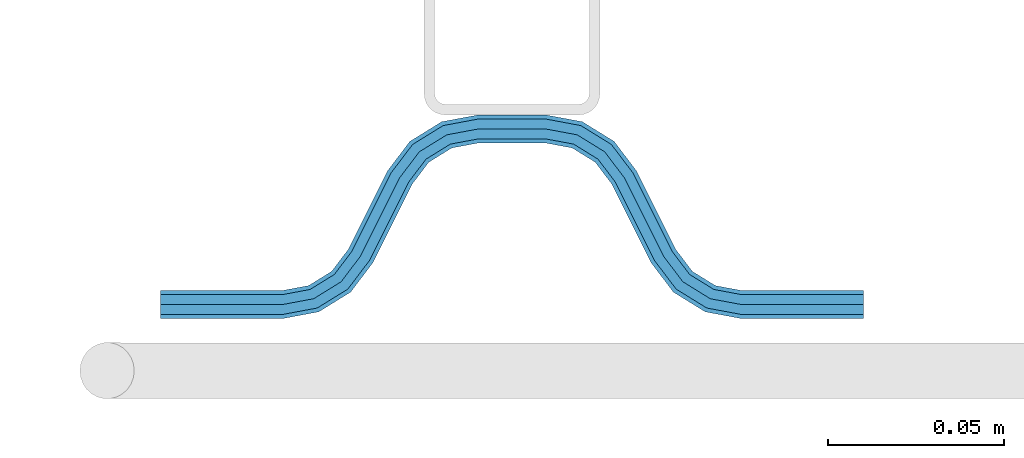
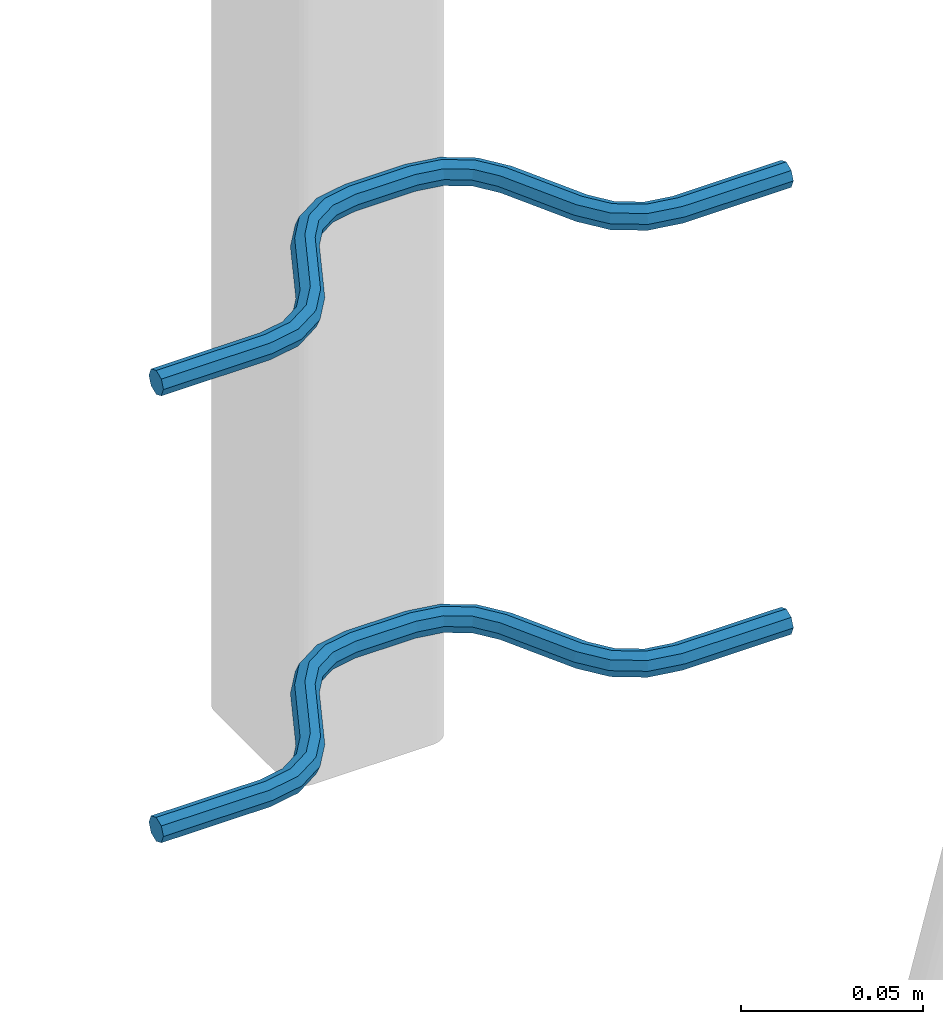
# One storey, part 4 of 5: 2 beams, 2 elements without a shape of their own.
"""IFC2X3 building model written with IfcOpenShell, lengths in millimetres."""

from ifc_helpers import new_model, si_unit, frame, origin_with_axes, place, context, subcontext, project, spatial, faceted_brep, material, type_object, element, aggregate, save


model = new_model("IFC2X3")

# Units and contexts
model_context = context("Model", 3, precision=1e-05, world=origin_with_axes())
body_context = subcontext(model_context, "Body", "Model", "MODEL_VIEW")
ifc_project = project(units=[si_unit("LENGTHUNIT", "METRE", prefix="MILLI"), si_unit("AREAUNIT", "SQUARE_METRE"), si_unit("VOLUMEUNIT", "CUBIC_METRE"), si_unit("MASSUNIT", "GRAM", prefix="KILO"), si_unit("TIMEUNIT", "SECOND"), si_unit("PLANEANGLEUNIT", "RADIAN"), si_unit("SOLIDANGLEUNIT", "STERADIAN"), si_unit("THERMODYNAMICTEMPERATUREUNIT", "DEGREE_CELSIUS"), si_unit("LUMINOUSINTENSITYUNIT", "LUMEN")], contexts=[model_context])

# Site, building, storey
site_placement = place(None, origin_with_axes())
site = spatial("IfcSite", under=ifc_project, at=site_placement, CompositionType="ELEMENT")
building_placement = place(site_placement, origin_with_axes())
building = spatial("IfcBuilding", under=site, at=building_placement, Name="Undefined", CompositionType="ELEMENT")
storey_placement = place(building_placement, origin_with_axes())
storey = spatial("IfcBuildingStorey", under=building, at=storey_placement, Name="Undefined", CompositionType="ELEMENT", Elevation=0.0)

# Assembly, beam
assembly_1_placement = place(storey_placement, origin_with_axes())
assembly_1 = element("IfcElementAssembly", 1, at=assembly_1_placement, inside=storey, Name="Steel Assembly", AssemblyPlace="NOTDEFINED", PredefinedType="NOTDEFINED")
ifc_material = material(Name="REBAR/A500HW")
beam_type = type_object("IfcBeamType", Name="D8", PredefinedType="NOTDEFINED")
beam_1_placement = place(assembly_1_placement, frame((36620.0028957805, 7595.98072202406, 2580.99992151562), z_axis=(0.0, 0.0, 1.0), x_axis=(-0.999999999544916, 3.01690000135643e-05, 0.0)))
beam_1 = element("IfcBeam", 2, at=beam_1_placement, type_object=beam_type, material=ifc_material, Name="AnchorRebar", ObjectType="D8", context=body_context, shape_type="Brep", body=[
    faceted_brep([(7.27595761418343e-12, -4.00000000000182, 0.0), (0.0, -2.82842712474667, -2.82842712474621), (34.5491497807379, -2.82842712464299, -2.82842712474621), (34.549149780345, -3.99999999990087, 0.0), (-7.27595761418343e-12, -1.81898940354586e-12, -4.0), (34.5491497807307, 1.02772901300341e-10, -4.0), (-1.45519152283669e-11, 2.82842712474485, -2.82842712474621), (34.5491497807234, 2.82842712484944, -2.82842712474621), (-2.18278728425503e-11, 3.99999999999909, 0.0), (34.5491497807234, 4.00000000010186, 0.0), (-1.45519152283669e-11, 2.82842712474485, 2.82842712474621), (34.5491497807234, 2.82842712484944, 2.82842712474621), (-7.27595761418343e-12, -1.81898940354586e-12, 4.0), (34.5491497807307, 1.02772901300341e-10, 4.0), (0.0, -2.82842712474667, 2.82842712474621), (34.5491497807379, -2.82842712464299, 2.82842712474621), (45.0102956729243, 2.04744769147965, 0.0), (44.5876751635515, 0.954756103194086, -2.82842712474621), (43.5673789981083, -1.68323474872432, -4.0), (42.5470828326725, -4.32122560063453, -2.82842712474621), (42.1244623233069, -5.41391718891373, 0.0), (42.5470828326725, -4.32122560063453, 2.82842712474621), (43.5673789981083, -1.68323474872432, 4.0), (44.5876751635515, 0.954756103194086, 2.82842712474621), (53.274424966643, -4.41395070837552, 2.82842712474621), (54.0627564232345, -3.54728092317691, 0.0), (51.3712244724884, -6.50627665790307, 4.0), (49.4680239783338, -8.59860260741789, 2.82842712474621), (48.6796925217277, -9.46527239261468, 0.0), (49.4680239783338, -8.59860260741789, -2.82842712474621), (51.3712244724884, -6.50627665790307, -4.0), (53.274424966643, -4.41395070837552, -2.82842712474621), (59.4396520594746, -12.5547498008682, 2.82842712474621), (60.4875387111679, -12.0308065146201, 0.0), (56.9098298930985, -13.8196607884374, 4.0), (54.3800077267297, -15.0845717760067, 2.82842712474621), (53.3321210758731, -15.6085150625322, 0.0), (54.3800077267297, -15.0845717760067, -2.82842712474621), (56.9098298930985, -13.8196607884374, -4.0), (59.4396520594746, -12.5547498008682, -2.82842712474621), (65.5603461600622, -37.4452503321163, -2.82842712474621), (64.5124595074158, -37.9691936177969, 0.0), (68.0901683264528, -36.1803393445689, -4.0), (70.6199904928435, -34.9154283570224, -2.82842712474621), (71.6678771445659, -34.3914850707852, 0.0), (70.6199904928435, -34.9154283570224, 2.82842712474621), (68.0901683264528, -36.1803393445689, 4.0), (65.5603461600622, -37.4452503321163, 2.82842712474621), (76.3203054721671, -40.5347275358472, 0.0), (75.5319740029881, -41.4013973096107, -2.82842712474621), (73.6287734785001, -43.493723231526, -4.0), (71.725572954012, -45.5860491534477, -2.82842712474621), (70.9372414848403, -46.4527189272058, 0.0), (71.725572954012, -45.5860491534477, 2.82842712474621), (73.6287734785001, -43.493723231526, 4.0), (75.5319740029881, -41.4013973096107, 2.82842712474621), (82.4529147876383, -45.678774301171, 2.82842712474621), (82.8755353286615, -44.5860827251427, 0.0), (81.4326185457467, -48.316765123519, 4.0), (80.4123223038623, -50.9547559458688, 2.82842712474621), (79.9897017628464, -52.0474475218998, 0.0), (80.4123223038623, -50.9547559458688, -2.82842712474621), (81.4326185457467, -48.316765123519, -4.0), (82.4529147876383, -45.678774301171, -2.82842712474621), (90.4508474761824, -47.1715730089909, 2.82842712474621), (90.4508475270486, -46.0000001337403, 0.0), (90.4508473533569, -50.0000001337421, 4.0), (90.4508472305388, -52.8284272584824, 2.82842712474621), (90.4508471810623, -54.0000001334192, 0.0), (90.4508472305388, -52.8284272584824, -2.82842712474621), (90.4508473533569, -50.0000001337421, -4.0), (90.4508474761824, -47.1715730089909, -2.82842712474621), (109.549147671314, -52.828428087013, -2.82842712474621), (109.549147618898, -54.0000009615114, 0.0), (109.549147794067, -50.0000009622654, -4.0), (109.549147916819, -47.1715738375196, -2.82842712474621), (109.549147967664, -46.0000009622663, 0.0), (109.549147916819, -47.1715738375196, 2.82842712474621), (109.549147794067, -50.0000009622654, 4.0), (109.549147671314, -52.828428087013, 2.82842712474621), (120.010293517989, -52.0474491371906, 0.0), (119.587673059206, -50.95475752935, 2.82842712474621), (118.567377015956, -48.3167666302052, 4.0), (117.547080972676, -45.6787757310622, 2.82842712474621), (117.124460513907, -44.5860841232252, 0.0), (117.547080972676, -45.6787757310622, -2.82842712474621), (118.567377015956, -48.3167666302052, -4.0), (119.587673059206, -50.95475752935, -2.82842712474621), (128.274423051225, -45.5860511742758, -2.82842712474621), (129.062754465151, -46.4527209982625, 0.0), (126.371222660033, -43.4937251311248, -4.0), (124.468022268848, -41.4013990879721, -2.82842712474621), (123.679690854893, -40.5347292639963, 0.0), (124.468022268848, -41.4013990879721, 2.82842712474621), (126.371222660033, -43.4937251311248, 4.0), (128.274423051225, -45.5860511742758, 2.82842712474621), (134.439650508539, -37.4452524573517, -2.82842712474621), (135.487537134875, -37.9691957980922, 0.0), (131.909828408097, -36.1803413379721, -4.0), (129.380006307656, -34.9154302185943, -2.82842712474621), (128.33211968324, -34.3914868777611, 0.0), (129.380006307656, -34.9154302185943, 2.82842712474621), (131.909828408097, -36.1803413379721, 4.0), (134.439650508539, -37.4452524573517, 2.82842712474621), (145.619991978034, -15.0845707426524, -2.82842712474621), (146.667878600529, -15.608514083453, 0.0), (143.090169877512, -13.8196596233502, -4.0), (140.560347776998, -12.554748504047, -2.82842712474621), (139.512461152575, -12.0308051632364, 0.0), (140.560347776998, -12.554748504047, 2.82842712474621), (143.090169877512, -13.8196596233502, 4.0), (145.619991978034, -15.0845707426524, 2.82842712474621), (151.320307204172, -9.46527190099096, 0.0), (150.531975777631, -8.59860208845839, 2.82842712474621), (148.628775356046, -6.50627607293518, 4.0), (146.725574934469, -4.41395005741288, 2.82842712474621), (145.937243507928, -3.54728024488213, 0.0), (146.725574934469, -4.41395005741288, -2.82842712474621), (148.628775356046, -6.50627607293518, -4.0), (150.531975777631, -8.59860208845839, -2.82842712474621), (157.452916713017, -4.32122546031951, -2.82842712474621), (157.875537203457, -5.4139170559065, 0.0), (156.432620593238, -1.68323459075327, -4.0), (155.41232447348, 0.954756278820241, -2.82842712474621), (154.989703983039, 2.04744787441359, 0.0), (155.41232447348, 0.954756278820241, 2.82842712474621), (156.432620593238, -1.68323459075327, 4.0), (157.452916713017, -4.32122546031951, 2.82842712474621), (165.450849406705, -2.8284271226612, -2.82842712474621), (165.450849408393, -3.9999999990614, 0.0), (165.45084940661, 2.0727384253405e-09, -4.0), (165.450849406516, 2.82842712681577, -2.82842712474621), (165.450849406494, 4.0000000020591, 0.0), (165.450849406516, 2.82842712681577, 2.82842712474621), (165.45084940661, 2.0727384253405e-09, 4.0), (165.450849406705, -2.8284271226612, 2.82842712474621), (200.000000089029, -2.82842712378351, -2.82842712474621), (200.000000089029, -3.99999999903866, 0.0), (200.000000089029, 9.61335899773985e-10, -4.0), (200.000000089021, 2.828427125708, -2.82842712474621), (200.000000089029, 4.00000000096134, 0.0), (200.000000089021, 2.828427125708, 2.82842712474621), (200.000000089029, 9.61335899773985e-10, 4.0), (200.000000089029, -2.82842712378351, 2.82842712474621)], [[[0, 1, 2, 3]], [[1, 4, 5, 2]], [[4, 6, 7, 5]], [[6, 8, 9, 7]], [[8, 10, 11, 9]], [[10, 12, 13, 11]], [[12, 14, 15, 13]], [[14, 0, 3, 15]], [[14, 12, 10, 8, 6, 4, 1, 0]], [[7, 9, 16, 17]], [[5, 7, 17, 18]], [[2, 5, 18, 19]], [[3, 2, 19, 20]], [[15, 3, 20, 21]], [[13, 15, 21, 22]], [[11, 13, 22, 23]], [[9, 11, 23, 16]], [[23, 24, 25, 16]], [[22, 26, 24, 23]], [[21, 27, 26, 22]], [[20, 28, 27, 21]], [[19, 29, 28, 20]], [[18, 30, 29, 19]], [[17, 31, 30, 18]], [[16, 25, 31, 17]], [[24, 32, 33, 25]], [[26, 34, 32, 24]], [[27, 35, 34, 26]], [[28, 36, 35, 27]], [[29, 37, 36, 28]], [[30, 38, 37, 29]], [[31, 39, 38, 30]], [[25, 33, 39, 31]], [[36, 37, 40, 41]], [[37, 38, 42, 40]], [[38, 39, 43, 42]], [[39, 33, 44, 43]], [[33, 32, 45, 44]], [[32, 34, 46, 45]], [[34, 35, 47, 46]], [[35, 36, 41, 47]], [[43, 44, 48, 49]], [[42, 43, 49, 50]], [[40, 42, 50, 51]], [[41, 40, 51, 52]], [[47, 41, 52, 53]], [[46, 47, 53, 54]], [[45, 46, 54, 55]], [[44, 45, 55, 48]], [[55, 56, 57, 48]], [[54, 58, 56, 55]], [[53, 59, 58, 54]], [[52, 60, 59, 53]], [[51, 61, 60, 52]], [[50, 62, 61, 51]], [[49, 63, 62, 50]], [[48, 57, 63, 49]], [[56, 64, 65, 57]], [[58, 66, 64, 56]], [[59, 67, 66, 58]], [[60, 68, 67, 59]], [[61, 69, 68, 60]], [[62, 70, 69, 61]], [[63, 71, 70, 62]], [[57, 65, 71, 63]], [[68, 69, 72, 73]], [[69, 70, 74, 72]], [[70, 71, 75, 74]], [[71, 65, 76, 75]], [[65, 64, 77, 76]], [[64, 66, 78, 77]], [[66, 67, 79, 78]], [[67, 68, 73, 79]], [[79, 73, 80, 81]], [[78, 79, 81, 82]], [[77, 78, 82, 83]], [[76, 77, 83, 84]], [[75, 76, 84, 85]], [[74, 75, 85, 86]], [[72, 74, 86, 87]], [[73, 72, 87, 80]], [[87, 88, 89, 80]], [[86, 90, 88, 87]], [[85, 91, 90, 86]], [[84, 92, 91, 85]], [[83, 93, 92, 84]], [[82, 94, 93, 83]], [[81, 95, 94, 82]], [[80, 89, 95, 81]], [[88, 96, 97, 89]], [[90, 98, 96, 88]], [[91, 99, 98, 90]], [[92, 100, 99, 91]], [[93, 101, 100, 92]], [[94, 102, 101, 93]], [[95, 103, 102, 94]], [[89, 97, 103, 95]], [[97, 96, 104, 105]], [[96, 98, 106, 104]], [[98, 99, 107, 106]], [[99, 100, 108, 107]], [[100, 101, 109, 108]], [[101, 102, 110, 109]], [[102, 103, 111, 110]], [[103, 97, 105, 111]], [[111, 105, 112, 113]], [[110, 111, 113, 114]], [[109, 110, 114, 115]], [[108, 109, 115, 116]], [[107, 108, 116, 117]], [[106, 107, 117, 118]], [[104, 106, 118, 119]], [[105, 104, 119, 112]], [[119, 120, 121, 112]], [[118, 122, 120, 119]], [[117, 123, 122, 118]], [[116, 124, 123, 117]], [[115, 125, 124, 116]], [[114, 126, 125, 115]], [[113, 127, 126, 114]], [[112, 121, 127, 113]], [[120, 128, 129, 121]], [[122, 130, 128, 120]], [[123, 131, 130, 122]], [[124, 132, 131, 123]], [[125, 133, 132, 124]], [[126, 134, 133, 125]], [[127, 135, 134, 126]], [[121, 129, 135, 127]], [[129, 128, 136, 137]], [[128, 130, 138, 136]], [[130, 131, 139, 138]], [[131, 132, 140, 139]], [[132, 133, 141, 140]], [[133, 134, 142, 141]], [[134, 135, 143, 142]], [[135, 129, 137, 143]], [[138, 139, 140, 141, 142, 143, 137, 136]]]),
])
aggregate(assembly_1, [beam_1])

assembly_2_placement = place(storey_placement, origin_with_axes())
assembly_2 = element("IfcElementAssembly", 3, at=assembly_2_placement, inside=storey, Name="Steel Assembly", AssemblyPlace="NOTDEFINED", PredefinedType="NOTDEFINED")
beam_2_placement = place(assembly_2_placement, frame((36620.0028957805, 7595.98072202406, 2430.99992151562), z_axis=(0.0, 0.0, 1.0), x_axis=(-0.999999999544916, 3.01690000135643e-05, 0.0)))
beam_2 = element("IfcBeam", 4, at=beam_2_placement, type_object=beam_type, material=ifc_material, Name="AnchorRebar", ObjectType="D8", context=body_context, shape_type="Brep", body=[
    faceted_brep([(7.27595761418343e-12, -4.00000000000182, 0.0), (0.0, -2.82842712474667, -2.82842712474621), (34.5491497807379, -2.82842712464299, -2.82842712474621), (34.549149780345, -3.99999999990087, 0.0), (-7.27595761418343e-12, -1.81898940354586e-12, -4.0), (34.5491497807307, 1.02772901300341e-10, -4.0), (-1.45519152283669e-11, 2.82842712474485, -2.82842712474621), (34.5491497807234, 2.82842712484944, -2.82842712474621), (-2.18278728425503e-11, 3.99999999999909, 0.0), (34.5491497807234, 4.00000000010186, 0.0), (-1.45519152283669e-11, 2.82842712474485, 2.82842712474621), (34.5491497807234, 2.82842712484944, 2.82842712474621), (-7.27595761418343e-12, -1.81898940354586e-12, 4.0), (34.5491497807307, 1.02772901300341e-10, 4.0), (0.0, -2.82842712474667, 2.82842712474621), (34.5491497807379, -2.82842712464299, 2.82842712474621), (45.0102956729243, 2.04744769147965, 0.0), (44.5876751635515, 0.954756103194086, -2.82842712474621), (43.5673789981083, -1.68323474872432, -4.0), (42.5470828326725, -4.32122560063453, -2.82842712474621), (42.1244623233069, -5.41391718891373, 0.0), (42.5470828326725, -4.32122560063453, 2.82842712474621), (43.5673789981083, -1.68323474872432, 4.0), (44.5876751635515, 0.954756103194086, 2.82842712474621), (53.274424966643, -4.41395070837552, 2.82842712474621), (54.0627564232345, -3.54728092317691, 0.0), (51.3712244724884, -6.50627665790307, 4.0), (49.4680239783338, -8.59860260741789, 2.82842712474621), (48.6796925217277, -9.46527239261468, 0.0), (49.4680239783338, -8.59860260741789, -2.82842712474621), (51.3712244724884, -6.50627665790307, -4.0), (53.274424966643, -4.41395070837552, -2.82842712474621), (59.4396520594746, -12.5547498008682, 2.82842712474621), (60.4875387111679, -12.0308065146201, 0.0), (56.9098298930985, -13.8196607884374, 4.0), (54.3800077267297, -15.0845717760067, 2.82842712474621), (53.3321210758731, -15.6085150625322, 0.0), (54.3800077267297, -15.0845717760067, -2.82842712474621), (56.9098298930985, -13.8196607884374, -4.0), (59.4396520594746, -12.5547498008682, -2.82842712474621), (65.5603461600622, -37.4452503321163, -2.82842712474621), (64.5124595074158, -37.9691936177969, 0.0), (68.0901683264528, -36.1803393445689, -4.0), (70.6199904928435, -34.9154283570224, -2.82842712474621), (71.6678771445659, -34.3914850707852, 0.0), (70.6199904928435, -34.9154283570224, 2.82842712474621), (68.0901683264528, -36.1803393445689, 4.0), (65.5603461600622, -37.4452503321163, 2.82842712474621), (76.3203054721671, -40.5347275358472, 0.0), (75.5319740029881, -41.4013973096107, -2.82842712474621), (73.6287734785001, -43.493723231526, -4.0), (71.725572954012, -45.5860491534477, -2.82842712474621), (70.9372414848403, -46.4527189272058, 0.0), (71.725572954012, -45.5860491534477, 2.82842712474621), (73.6287734785001, -43.493723231526, 4.0), (75.5319740029881, -41.4013973096107, 2.82842712474621), (82.4529147876383, -45.678774301171, 2.82842712474621), (82.8755353286615, -44.5860827251427, 0.0), (81.4326185457467, -48.316765123519, 4.0), (80.4123223038623, -50.9547559458688, 2.82842712474621), (79.9897017628464, -52.0474475218998, 0.0), (80.4123223038623, -50.9547559458688, -2.82842712474621), (81.4326185457467, -48.316765123519, -4.0), (82.4529147876383, -45.678774301171, -2.82842712474621), (90.4508474761824, -47.1715730089909, 2.82842712474621), (90.4508475270486, -46.0000001337403, 0.0), (90.4508473533569, -50.0000001337421, 4.0), (90.4508472305388, -52.8284272584824, 2.82842712474621), (90.4508471810623, -54.0000001334192, 0.0), (90.4508472305388, -52.8284272584824, -2.82842712474621), (90.4508473533569, -50.0000001337421, -4.0), (90.4508474761824, -47.1715730089909, -2.82842712474621), (109.549147671314, -52.828428087013, -2.82842712474621), (109.549147618898, -54.0000009615114, 0.0), (109.549147794067, -50.0000009622654, -4.0), (109.549147916819, -47.1715738375196, -2.82842712474621), (109.549147967664, -46.0000009622663, 0.0), (109.549147916819, -47.1715738375196, 2.82842712474621), (109.549147794067, -50.0000009622654, 4.0), (109.549147671314, -52.828428087013, 2.82842712474621), (120.010293517989, -52.0474491371906, 0.0), (119.587673059206, -50.95475752935, 2.82842712474621), (118.567377015956, -48.3167666302052, 4.0), (117.547080972676, -45.6787757310622, 2.82842712474621), (117.124460513907, -44.5860841232252, 0.0), (117.547080972676, -45.6787757310622, -2.82842712474621), (118.567377015956, -48.3167666302052, -4.0), (119.587673059206, -50.95475752935, -2.82842712474621), (128.274423051225, -45.5860511742758, -2.82842712474621), (129.062754465151, -46.4527209982625, 0.0), (126.371222660033, -43.4937251311248, -4.0), (124.468022268848, -41.4013990879721, -2.82842712474621), (123.679690854893, -40.5347292639963, 0.0), (124.468022268848, -41.4013990879721, 2.82842712474621), (126.371222660033, -43.4937251311248, 4.0), (128.274423051225, -45.5860511742758, 2.82842712474621), (134.439650508539, -37.4452524573517, -2.82842712474621), (135.487537134875, -37.9691957980922, 0.0), (131.909828408097, -36.1803413379721, -4.0), (129.380006307656, -34.9154302185943, -2.82842712474621), (128.33211968324, -34.3914868777611, 0.0), (129.380006307656, -34.9154302185943, 2.82842712474621), (131.909828408097, -36.1803413379721, 4.0), (134.439650508539, -37.4452524573517, 2.82842712474621), (145.619991978034, -15.0845707426524, -2.82842712474621), (146.667878600529, -15.608514083453, 0.0), (143.090169877512, -13.8196596233502, -4.0), (140.560347776998, -12.554748504047, -2.82842712474621), (139.512461152575, -12.0308051632364, 0.0), (140.560347776998, -12.554748504047, 2.82842712474621), (143.090169877512, -13.8196596233502, 4.0), (145.619991978034, -15.0845707426524, 2.82842712474621), (151.320307204172, -9.46527190099096, 0.0), (150.531975777631, -8.59860208845839, 2.82842712474621), (148.628775356046, -6.50627607293518, 4.0), (146.725574934469, -4.41395005741288, 2.82842712474621), (145.937243507928, -3.54728024488213, 0.0), (146.725574934469, -4.41395005741288, -2.82842712474621), (148.628775356046, -6.50627607293518, -4.0), (150.531975777631, -8.59860208845839, -2.82842712474621), (157.452916713017, -4.32122546031951, -2.82842712474621), (157.875537203457, -5.4139170559065, 0.0), (156.432620593238, -1.68323459075327, -4.0), (155.41232447348, 0.954756278820241, -2.82842712474621), (154.989703983039, 2.04744787441359, 0.0), (155.41232447348, 0.954756278820241, 2.82842712474621), (156.432620593238, -1.68323459075327, 4.0), (157.452916713017, -4.32122546031951, 2.82842712474621), (165.450849406705, -2.8284271226612, -2.82842712474621), (165.450849408393, -3.9999999990614, 0.0), (165.45084940661, 2.0727384253405e-09, -4.0), (165.450849406516, 2.82842712681577, -2.82842712474621), (165.450849406494, 4.0000000020591, 0.0), (165.450849406516, 2.82842712681577, 2.82842712474621), (165.45084940661, 2.0727384253405e-09, 4.0), (165.450849406705, -2.8284271226612, 2.82842712474621), (200.000000089029, -2.82842712378351, -2.82842712474621), (200.000000089029, -3.99999999903866, 0.0), (200.000000089029, 9.61335899773985e-10, -4.0), (200.000000089021, 2.828427125708, -2.82842712474621), (200.000000089029, 4.00000000096134, 0.0), (200.000000089021, 2.828427125708, 2.82842712474621), (200.000000089029, 9.61335899773985e-10, 4.0), (200.000000089029, -2.82842712378351, 2.82842712474621)], [[[0, 1, 2, 3]], [[1, 4, 5, 2]], [[4, 6, 7, 5]], [[6, 8, 9, 7]], [[8, 10, 11, 9]], [[10, 12, 13, 11]], [[12, 14, 15, 13]], [[14, 0, 3, 15]], [[14, 12, 10, 8, 6, 4, 1, 0]], [[7, 9, 16, 17]], [[5, 7, 17, 18]], [[2, 5, 18, 19]], [[3, 2, 19, 20]], [[15, 3, 20, 21]], [[13, 15, 21, 22]], [[11, 13, 22, 23]], [[9, 11, 23, 16]], [[23, 24, 25, 16]], [[22, 26, 24, 23]], [[21, 27, 26, 22]], [[20, 28, 27, 21]], [[19, 29, 28, 20]], [[18, 30, 29, 19]], [[17, 31, 30, 18]], [[16, 25, 31, 17]], [[24, 32, 33, 25]], [[26, 34, 32, 24]], [[27, 35, 34, 26]], [[28, 36, 35, 27]], [[29, 37, 36, 28]], [[30, 38, 37, 29]], [[31, 39, 38, 30]], [[25, 33, 39, 31]], [[36, 37, 40, 41]], [[37, 38, 42, 40]], [[38, 39, 43, 42]], [[39, 33, 44, 43]], [[33, 32, 45, 44]], [[32, 34, 46, 45]], [[34, 35, 47, 46]], [[35, 36, 41, 47]], [[43, 44, 48, 49]], [[42, 43, 49, 50]], [[40, 42, 50, 51]], [[41, 40, 51, 52]], [[47, 41, 52, 53]], [[46, 47, 53, 54]], [[45, 46, 54, 55]], [[44, 45, 55, 48]], [[55, 56, 57, 48]], [[54, 58, 56, 55]], [[53, 59, 58, 54]], [[52, 60, 59, 53]], [[51, 61, 60, 52]], [[50, 62, 61, 51]], [[49, 63, 62, 50]], [[48, 57, 63, 49]], [[56, 64, 65, 57]], [[58, 66, 64, 56]], [[59, 67, 66, 58]], [[60, 68, 67, 59]], [[61, 69, 68, 60]], [[62, 70, 69, 61]], [[63, 71, 70, 62]], [[57, 65, 71, 63]], [[68, 69, 72, 73]], [[69, 70, 74, 72]], [[70, 71, 75, 74]], [[71, 65, 76, 75]], [[65, 64, 77, 76]], [[64, 66, 78, 77]], [[66, 67, 79, 78]], [[67, 68, 73, 79]], [[79, 73, 80, 81]], [[78, 79, 81, 82]], [[77, 78, 82, 83]], [[76, 77, 83, 84]], [[75, 76, 84, 85]], [[74, 75, 85, 86]], [[72, 74, 86, 87]], [[73, 72, 87, 80]], [[87, 88, 89, 80]], [[86, 90, 88, 87]], [[85, 91, 90, 86]], [[84, 92, 91, 85]], [[83, 93, 92, 84]], [[82, 94, 93, 83]], [[81, 95, 94, 82]], [[80, 89, 95, 81]], [[88, 96, 97, 89]], [[90, 98, 96, 88]], [[91, 99, 98, 90]], [[92, 100, 99, 91]], [[93, 101, 100, 92]], [[94, 102, 101, 93]], [[95, 103, 102, 94]], [[89, 97, 103, 95]], [[97, 96, 104, 105]], [[96, 98, 106, 104]], [[98, 99, 107, 106]], [[99, 100, 108, 107]], [[100, 101, 109, 108]], [[101, 102, 110, 109]], [[102, 103, 111, 110]], [[103, 97, 105, 111]], [[111, 105, 112, 113]], [[110, 111, 113, 114]], [[109, 110, 114, 115]], [[108, 109, 115, 116]], [[107, 108, 116, 117]], [[106, 107, 117, 118]], [[104, 106, 118, 119]], [[105, 104, 119, 112]], [[119, 120, 121, 112]], [[118, 122, 120, 119]], [[117, 123, 122, 118]], [[116, 124, 123, 117]], [[115, 125, 124, 116]], [[114, 126, 125, 115]], [[113, 127, 126, 114]], [[112, 121, 127, 113]], [[120, 128, 129, 121]], [[122, 130, 128, 120]], [[123, 131, 130, 122]], [[124, 132, 131, 123]], [[125, 133, 132, 124]], [[126, 134, 133, 125]], [[127, 135, 134, 126]], [[121, 129, 135, 127]], [[129, 128, 136, 137]], [[128, 130, 138, 136]], [[130, 131, 139, 138]], [[131, 132, 140, 139]], [[132, 133, 141, 140]], [[133, 134, 142, 141]], [[134, 135, 143, 142]], [[135, 129, 137, 143]], [[138, 139, 140, 141, 142, 143, 137, 136]]]),
])
aggregate(assembly_2, [beam_2])

save(model, "model.ifc")
